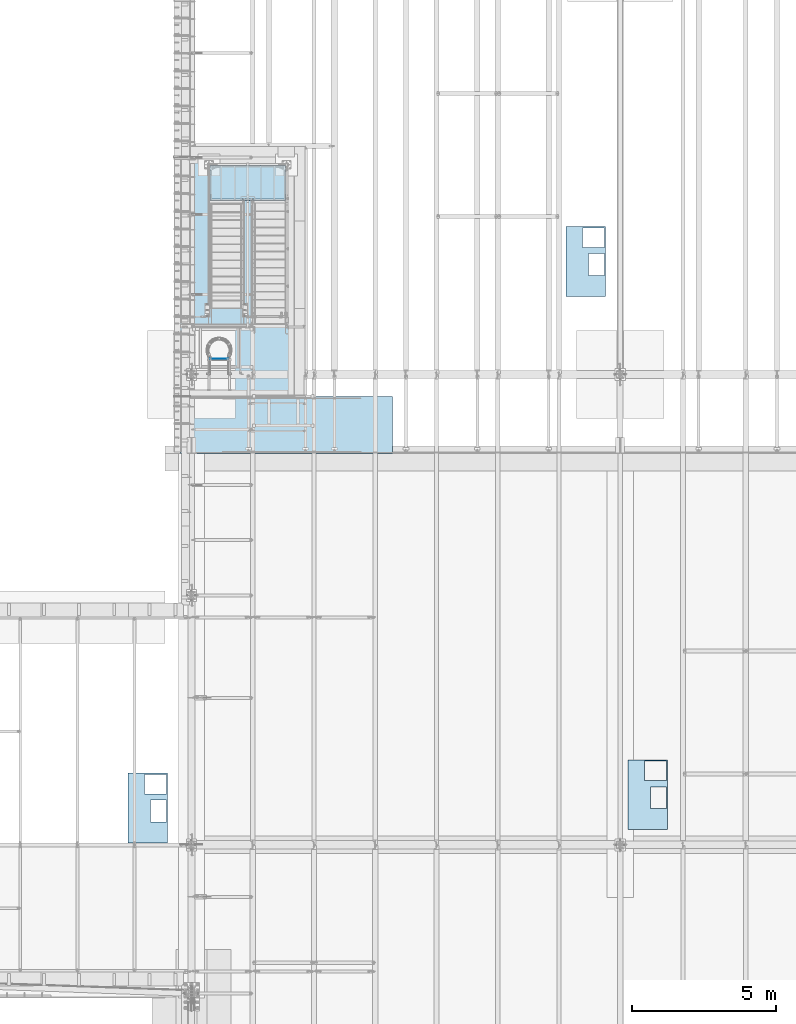
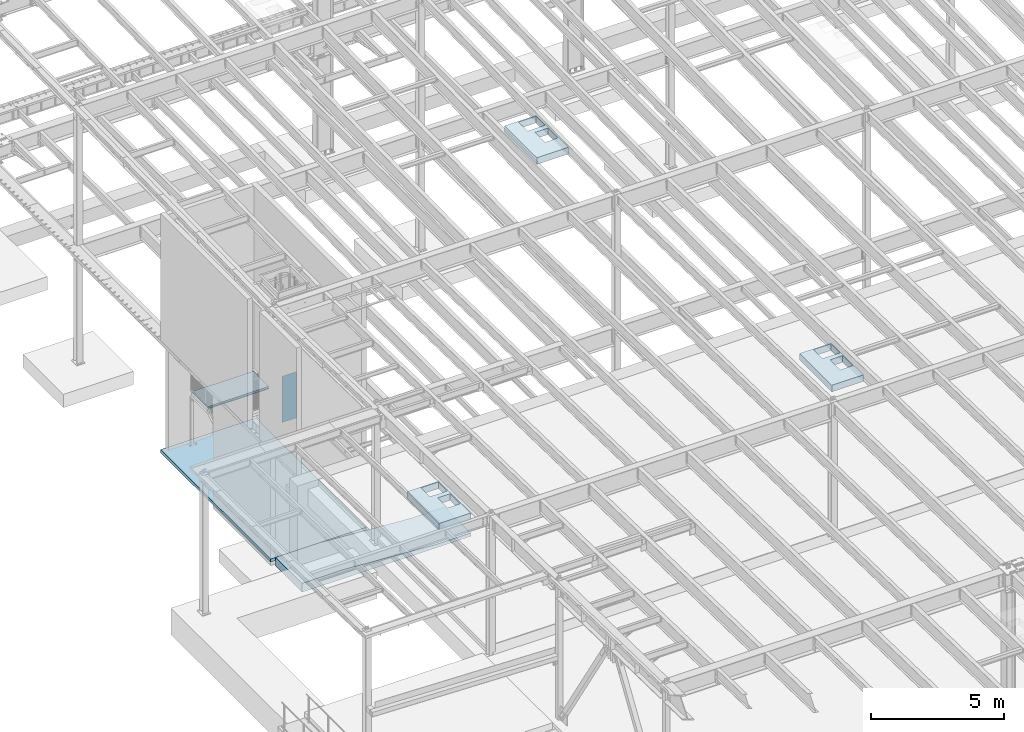
# One storey, part 1413 of 1763: 5 plates, 3 slabs, 8 elements without a shape of their own.
"""IFC2X3 building model written with IfcOpenShell, lengths in millimetres."""

from ifc_helpers import new_model, si_unit, frame, origin_with_axes, place, context, subcontext, project, spatial, faceted_brep, material, type_object, element, aggregate, save


model = new_model("IFC2X3")

# Units and contexts
model_context = context("Model", 3, precision=1e-05, world=origin_with_axes())
body_context = subcontext(model_context, "Body", "Model", "MODEL_VIEW")
ifc_project = project(units=[si_unit("LENGTHUNIT", "METRE", prefix="MILLI"), si_unit("AREAUNIT", "SQUARE_METRE"), si_unit("VOLUMEUNIT", "CUBIC_METRE"), si_unit("MASSUNIT", "GRAM", prefix="KILO"), si_unit("TIMEUNIT", "SECOND"), si_unit("PLANEANGLEUNIT", "RADIAN"), si_unit("SOLIDANGLEUNIT", "STERADIAN"), si_unit("THERMODYNAMICTEMPERATUREUNIT", "DEGREE_CELSIUS"), si_unit("LUMINOUSINTENSITYUNIT", "LUMEN")], contexts=[model_context])

# Site, building, storey
site_placement = place(None, origin_with_axes())
site = spatial("IfcSite", under=ifc_project, at=site_placement, CompositionType="ELEMENT")
building_placement = place(site_placement, origin_with_axes())
building = spatial("IfcBuilding", under=site, at=building_placement, Name="Undefined", CompositionType="ELEMENT")
storey_placement = place(building_placement, origin_with_axes())
storey = spatial("IfcBuildingStorey", under=building, at=storey_placement, Name="Undefined", CompositionType="ELEMENT", Elevation=0.0)

# Assembly, plate
assembly_1_placement = place(storey_placement, origin_with_axes())
assembly_1 = element("IfcElementAssembly", 1, at=assembly_1_placement, inside=storey, Name="B-BOX", AssemblyPlace="NOTDEFINED", PredefinedType="RIGID_FRAME")
ifc_material_1 = material(Name="STEEL/A36")
plate_type_1 = type_object("IfcPlateType", PredefinedType="NOTDEFINED")
plate_1_placement = place(assembly_1_placement, frame((-88202.1570503235, 16185.7148888111, 11747.5), z_axis=(0.0, -1.0, 0.0), x_axis=(-1.0, 0.0, 0.0)))
plate_1 = element("IfcPlate", 2, at=plate_1_placement, type_object=plate_type_1, material=ifc_material_1, Name="B-BOX", context=body_context, shape_type="Brep", body=[
    faceted_brep([(596.899999999994, -152.4, 1691.12592269852), (596.899999999994, 152.4, 1691.12592269852), (596.899999999994, 152.4, 939.803901214145), (596.899999999994, -152.4, 939.803901214145), (44.4499877929629, 152.4, 939.803901214145), (44.4499877929629, -152.4, 939.803901214145), (44.4499877929629, 152.4, 1695.45388175919), (44.4499877929629, -152.4, 1695.45388175919), (596.899999999994, 152.4, 1695.45388175919), (596.899999999994, -152.4, 1695.45388175919), (1377.94995117188, -152.4, 0.0), (0.0, -152.4, 0.0), (0.0, 152.4, 0.0), (1377.94995117188, 152.4, 0.0), (1377.94995117188, -152.4, 2422.52490234375), (1377.94995117188, 152.4, 2422.52490234375), (0.0, -152.4, 2422.52490234375), (0.0, 152.4, 2422.52490234375), (44.4499999999971, -152.4, 44.4499999999971), (44.4500244140654, -152.4, 723.903857421872), (800.091015625003, -152.4, 723.903857421872), (800.091015625003, -152.4, 44.4499999999971), (44.4499999999971, 152.4, 44.4499999999971), (44.4500244140654, 152.4, 723.903857421872), (800.091015625003, 152.4, 44.4499999999971), (800.091015625003, 152.4, 723.903857421872)], [[[0, 1, 2, 3]], [[3, 2, 4, 5]], [[5, 4, 6, 7]], [[7, 6, 8, 9]], [[9, 8, 1, 0]], [[10, 11, 12, 13]], [[14, 10, 13, 15]], [[16, 14, 15, 17]], [[11, 16, 17, 12]], [[10, 14, 16, 11], [3, 5, 7, 9, 0], [18, 19, 20, 21]], [[18, 22, 23, 19]], [[21, 24, 22, 18]], [[20, 25, 24, 21]], [[19, 23, 25, 20]], [[15, 13, 12, 17], [4, 2, 1, 8, 6], [22, 24, 25, 23]]]),
])
aggregate(assembly_1, [plate_1])

assembly_2_placement = place(storey_placement, origin_with_axes())
assembly_2 = element("IfcElementAssembly", 3, at=assembly_2_placement, inside=storey, Name="B-BOX", AssemblyPlace="NOTDEFINED", PredefinedType="RIGID_FRAME")
plate_2_placement = place(assembly_2_placement, frame((-70847.7068244934, 16646.6066124439, 11747.5), z_axis=(0.0, -1.0, 0.0), x_axis=(-1.0, 0.0, 0.0)))
plate_2 = element("IfcPlate", 4, at=plate_2_placement, type_object=plate_type_1, material=ifc_material_1, Name="B-BOX", context=body_context, shape_type="Brep", body=[
    faceted_brep([(596.899999999994, -152.4, 1691.12592269852), (596.899999999994, 152.4, 1691.12592269852), (596.899999999994, 152.4, 939.803901214145), (596.899999999994, -152.4, 939.803901214145), (44.4499877929629, 152.4, 939.803901214145), (44.4499877929629, -152.4, 939.803901214145), (44.4499877929629, 152.4, 1695.45388175919), (44.4499877929629, -152.4, 1695.45388175919), (596.899999999994, 152.4, 1695.45388175919), (596.899999999994, -152.4, 1695.45388175919), (1377.94995117188, -152.4, 0.0), (0.0, -152.4, 0.0), (0.0, 152.4, 0.0), (1377.94995117188, 152.4, 0.0), (1377.94995117188, -152.4, 2422.52490234375), (1377.94995117188, 152.4, 2422.52490234375), (0.0, -152.4, 2422.52490234375), (0.0, 152.4, 2422.52490234375), (44.4499999999971, -152.4, 44.4499999999971), (44.4500244140654, -152.4, 723.903857421872), (800.091015625003, -152.4, 723.903857421872), (800.091015625003, -152.4, 44.4499999999971), (44.4499999999971, 152.4, 44.4499999999971), (44.4500244140654, 152.4, 723.903857421872), (800.091015625003, 152.4, 44.4499999999971), (800.091015625003, 152.4, 723.903857421872)], [[[0, 1, 2, 3]], [[3, 2, 4, 5]], [[5, 4, 6, 7]], [[7, 6, 8, 9]], [[9, 8, 1, 0]], [[10, 11, 12, 13]], [[14, 10, 13, 15]], [[16, 14, 15, 17]], [[11, 16, 17, 12]], [[10, 14, 16, 11], [3, 5, 7, 9, 0], [18, 19, 20, 21]], [[18, 22, 23, 19]], [[21, 24, 22, 18]], [[20, 25, 24, 21]], [[19, 23, 25, 20]], [[15, 13, 12, 17], [4, 2, 1, 8, 6], [22, 24, 25, 23]]]),
])
aggregate(assembly_2, [plate_2])

assembly_3_placement = place(storey_placement, origin_with_axes())
assembly_3 = element("IfcElementAssembly", 5, at=assembly_3_placement, inside=storey, Name="B-BOX", AssemblyPlace="NOTDEFINED", PredefinedType="RIGID_FRAME")
plate_3_placement = place(assembly_3_placement, frame((-72999.4564353943, 35159.5956566334, 11747.5), z_axis=(0.0, -1.0, 0.0), x_axis=(-1.0, 0.0, 0.0)))
plate_3 = element("IfcPlate", 6, at=plate_3_placement, type_object=plate_type_1, material=ifc_material_1, Name="B-BOX", context=body_context, shape_type="Brep", body=[
    faceted_brep([(596.899999999994, -152.4, 1691.12592269852), (596.899999999994, 152.4, 1691.12592269852), (596.899999999994, 152.4, 939.803901214145), (596.899999999994, -152.4, 939.803901214145), (44.4499877929629, 152.4, 939.803901214145), (44.4499877929629, -152.4, 939.803901214145), (44.4499877929629, 152.4, 1695.45388175919), (44.4499877929629, -152.4, 1695.45388175919), (596.899999999994, 152.4, 1695.45388175919), (596.899999999994, -152.4, 1695.45388175919), (1377.94995117188, -152.4, 0.0), (0.0, -152.4, 0.0), (0.0, 152.4, 0.0), (1377.94995117188, 152.4, 0.0), (1377.94995117188, -152.4, 2422.52490234375), (1377.94995117188, 152.4, 2422.52490234375), (0.0, -152.4, 2422.52490234375), (0.0, 152.4, 2422.52490234375), (44.4499999999971, -152.4, 44.4499999999971), (44.4500244140654, -152.4, 723.903857421872), (800.091015625003, -152.4, 723.903857421872), (800.091015625003, -152.4, 44.4499999999971), (44.4499999999971, 152.4, 44.4499999999971), (44.4500244140654, 152.4, 723.903857421872), (800.091015625003, 152.4, 44.4499999999971), (800.091015625003, 152.4, 723.903857421872)], [[[0, 1, 2, 3]], [[3, 2, 4, 5]], [[5, 4, 6, 7]], [[7, 6, 8, 9]], [[9, 8, 1, 0]], [[10, 11, 12, 13]], [[14, 10, 13, 15]], [[16, 14, 15, 17]], [[11, 16, 17, 12]], [[10, 14, 16, 11], [3, 5, 7, 9, 0], [18, 19, 20, 21]], [[18, 22, 23, 19]], [[21, 24, 22, 18]], [[20, 25, 24, 21]], [[19, 23, 25, 20]], [[15, 13, 12, 17], [4, 2, 1, 8, 6], [22, 24, 25, 23]]]),
])
aggregate(assembly_3, [plate_3])

assembly_4_placement = place(storey_placement, origin_with_axes())
assembly_4 = element("IfcElementAssembly", 7, at=assembly_4_placement, inside=storey, Name="LADDER", AssemblyPlace="NOTDEFINED", PredefinedType="RIGID_FRAME")
plate_type_2 = type_object("IfcPlateType", PredefinedType="NOTDEFINED")
plate_4_placement = place(assembly_4_placement, frame((-86724.5622736991, 30572.075, 5346.70000000001), z_axis=(1.0, 0.0, 0.0), x_axis=(0.0, 0.0, 1.0)))
plate_4 = element("IfcPlate", 8, at=plate_4_placement, type_object=plate_type_2, material=ifc_material_1, Name="PLATE", context=body_context, shape_type="Brep", body=[
    faceted_brep([(1.81898940354586e-12, -3.17500000000291, 0.0), (-3.63797880709171e-11, -3.17499999999927, 628.650024414062), (-3.63797880709171e-11, 3.17499999999927, 628.650024414062), (-1.81898940354586e-12, 3.17499999997381, 0.0), (2133.60009765625, -3.17499999999927, 628.650024414062), (2133.60009765625, 3.17499999999927, 628.650024414062), (2133.60009765625, -3.17499999999927, -2.47382558882236e-10), (2133.60009765625, 3.17499999999927, -2.47382558882236e-10)], [[[0, 1, 2, 3]], [[1, 4, 5, 2]], [[4, 6, 7, 5]], [[6, 0, 3, 7]], [[5, 7, 3, 2]], [[6, 4, 1, 0]]]),
])
aggregate(assembly_4, [plate_4])

# Assembly, slab
assembly_5_placement = place(storey_placement, origin_with_axes())
assembly_5 = element("IfcElementAssembly", 9, at=assembly_5_placement, inside=storey, Name="SLAB", AssemblyPlace="NOTDEFINED", PredefinedType="REINFORCEMENT_UNIT")
ifc_material_2 = material(Name="CONCRETE/3000")
slab_type_1 = type_object("IfcSlabType", PredefinedType="NOTDEFINED")
slab_1_placement = place(assembly_5_placement, frame((-83806.7372736983, 37566.6, 228.6), z_axis=(0.0, -1.0, 0.0), x_axis=(-1.0, 0.0, 0.0)))
slab_1 = element("IfcSlab", 10, at=slab_1_placement, type_object=slab_type_1, material=ifc_material_2, Name="SLAB", PredefinedType="FLOOR", context=body_context, shape_type="Brep", body=[
    faceted_brep([(0.0, -76.2, 0.0), (0.0, -76.2, 8305.7998046875), (0.0, 76.2, 8305.7998046875), (0.0, 76.2, 0.0), (4159.25, -76.2, 8305.7998046875), (4159.25, 76.2, 8305.7998046875), (4159.25, -76.2, 0.0), (4159.25, 76.2, 0.0)], [[[0, 1, 2, 3]], [[1, 4, 5, 2]], [[4, 6, 7, 5]], [[6, 0, 3, 7]], [[5, 7, 3, 2]], [[6, 4, 1, 0]]]),
])
aggregate(assembly_5, [slab_1])

assembly_6_placement = place(storey_placement, origin_with_axes())
assembly_6 = element("IfcElementAssembly", 11, at=assembly_6_placement, inside=storey, Name="SLAB", AssemblyPlace="NOTDEFINED", PredefinedType="REINFORCEMENT_UNIT")
slab_type_2 = type_object("IfcSlabType", PredefinedType="NOTDEFINED")
slab_2_placement = place(assembly_6_placement, frame((-80392.4418464686, 28270.2, -104.775), z_axis=(-1.0, 0.0, 0.0), x_axis=(0.0, 0.0, 1.0)))
slab_2 = element("IfcSlab", 12, at=slab_2_placement, type_object=slab_type_2, material=ifc_material_2, Name="SLAB", PredefinedType="FLOOR", context=body_context, shape_type="Brep", body=[
    faceted_brep([(0.0, -990.599999999999, 0.0), (-4.29980991611956e-06, -990.599999999999, 7357.6455078125), (-4.29980991611956e-06, 990.599999999999, 7357.6455078125), (0.0, 990.599999999999, 0.0), (409.575012207031, -990.599999999999, 7357.6455078125), (409.575012207031, 990.599999999999, 7357.6455078125), (409.575012207031, -990.599999999999, 5478.04541015625), (409.575012207031, 990.599999999999, 5478.04541015625), (152.399993896484, -990.599999999999, 1524.0), (152.399993896484, 990.599999999999, 1524.0), (152.399993896484, -990.599999999999, 0.0), (152.399993896484, 990.599999999999, 0.0)], [[[0, 1, 2, 3]], [[1, 4, 5, 2]], [[4, 6, 7, 5]], [[6, 8, 9, 7]], [[8, 10, 11, 9]], [[10, 0, 3, 11]], [[5, 7, 9, 11, 3, 2]], [[10, 8, 6, 4, 1, 0]]]),
])
aggregate(assembly_6, [slab_2])

assembly_7_placement = place(storey_placement, origin_with_axes())
assembly_7 = element("IfcElementAssembly", 13, at=assembly_7_placement, inside=storey, Name="LANDING", AssemblyPlace="NOTDEFINED", PredefinedType="REINFORCEMENT_UNIT")
ifc_material_3 = material(Name="CONCRETE/5000")
slab_type_3 = type_object("IfcSlabType", PredefinedType="NOTDEFINED")
slab_3_placement = place(assembly_7_placement, frame((-84098.8372741202, 36106.1000011846, 2693.98749999997), z_axis=(-1.0, 0.0, 0.0), x_axis=(0.0, 1.0, 0.0)))
slab_3 = element("IfcSlab", 14, at=slab_3_placement, type_object=slab_type_3, material=ifc_material_3, Name="LANDING", PredefinedType="FLOOR", context=body_context, shape_type="Brep", body=[
    faceted_brep([(0.0, -38.0999984741211, 0.0), (-1.63004006026313e-06, -38.0999999999999, 2641.59985351562), (-1.63004006026313e-06, 38.0999999999999, 2641.59985351562), (0.0, 38.0999984741211, 0.0), (1168.39990234375, -38.0999999999999, 2641.59985351562), (1168.39990234375, 38.0999999999999, 2641.59985351562), (1168.39990234375, -38.0999999999999, -5.0931703299284e-10), (1168.39990234375, 38.0999999999999, -5.0931703299284e-10)], [[[0, 1, 2, 3]], [[1, 4, 5, 2]], [[4, 6, 7, 5]], [[6, 0, 3, 7]], [[5, 7, 3, 2]], [[6, 4, 1, 0]]]),
])
aggregate(assembly_7, [slab_3])

# Assembly, plate
assembly_8_placement = place(storey_placement, origin_with_axes())
assembly_8 = element("IfcElementAssembly", 15, at=assembly_8_placement, inside=storey, Name="LANDING PAN", AssemblyPlace="NOTDEFINED", PredefinedType="RIGID_FRAME")
plate_type_3 = type_object("IfcPlateType", PredefinedType="NOTDEFINED")
plate_5_placement = place(assembly_8_placement, frame((-84105.1872741202, 36061.6500011846, 2657.47499999996), z_axis=(-1.0, 0.0, 0.0), x_axis=(0.0, 1.0, 0.0)))
plate_5 = element("IfcPlate", 16, at=plate_5_placement, type_object=plate_type_3, material=ifc_material_1, Name="LANDING PAN", context=body_context, shape_type="Brep", body=[
    faceted_brep([(76.2001714004509, -1.58750000000009, 1130.30029998699), (76.2001714004509, 1.58750000000009, 1130.30029998699), (-7.23441189620644e-07, 1.58750000000009, 1130.30027268773), (-7.23441189620644e-07, -1.58750000000009, 1130.30027268773), (76.20003645002, -1.58750000000009, 1150.87232719338), (76.20003645002, 1.58750000000009, 1150.87232719338), (-7.36610672902316e-07, -1.58750000000009, 1150.87205340657), (-7.36610672902316e-07, 1.58750000000009, 1150.87205340657), (76.2003761208689, -1.58750000000009, 1477.96249985312), (76.2003761208689, 1.58750000000009, 1477.96249985312), (-9.45961801335216e-07, 1.58750000000009, 1477.96247255379), (-9.45961801335216e-07, -1.58750000000009, 1477.96247255379), (76.2002180459458, -1.58750000000009, 1498.600296255), (76.2002180459458, 1.58750000000009, 1498.600296255), (-9.59167664404958e-07, -1.58750000000009, 1498.60002246752), (-9.59167664404958e-07, 1.58750000000009, 1498.60002246752), (-1.6826088540256e-06, -1.58750000000009, 2628.90014648438), (-1.6826088540256e-06, 1.58750000000009, 2628.90014648438), (1206.5, -1.58750000000009, 2628.90014648438), (1206.5, 1.58750000000009, 2628.90014648438), (1206.5, -1.58750000000009, -5.23868948221207e-10), (1206.5, 1.58750000000009, -5.23868948221207e-10), (0.0, -1.58750000000009, 0.0), (0.0, 1.58750000000009, 0.0)], [[[0, 1, 2, 3]], [[4, 5, 1, 0]], [[6, 7, 5, 4]], [[8, 9, 10, 11]], [[12, 13, 9, 8]], [[14, 15, 13, 12]], [[16, 17, 15, 14]], [[16, 18, 19, 17]], [[18, 20, 21, 19]], [[20, 22, 23, 21]], [[23, 22, 3, 2]], [[10, 9, 13, 15, 17, 19, 21, 23, 2, 1, 5, 7]], [[11, 10, 7, 6]], [[3, 22, 20, 18, 16, 14, 12, 8, 11, 6, 4, 0]]]),
])
aggregate(assembly_8, [plate_5])

save(model, "model.ifc")
